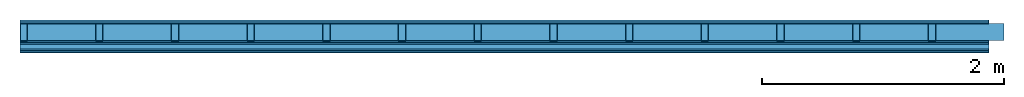
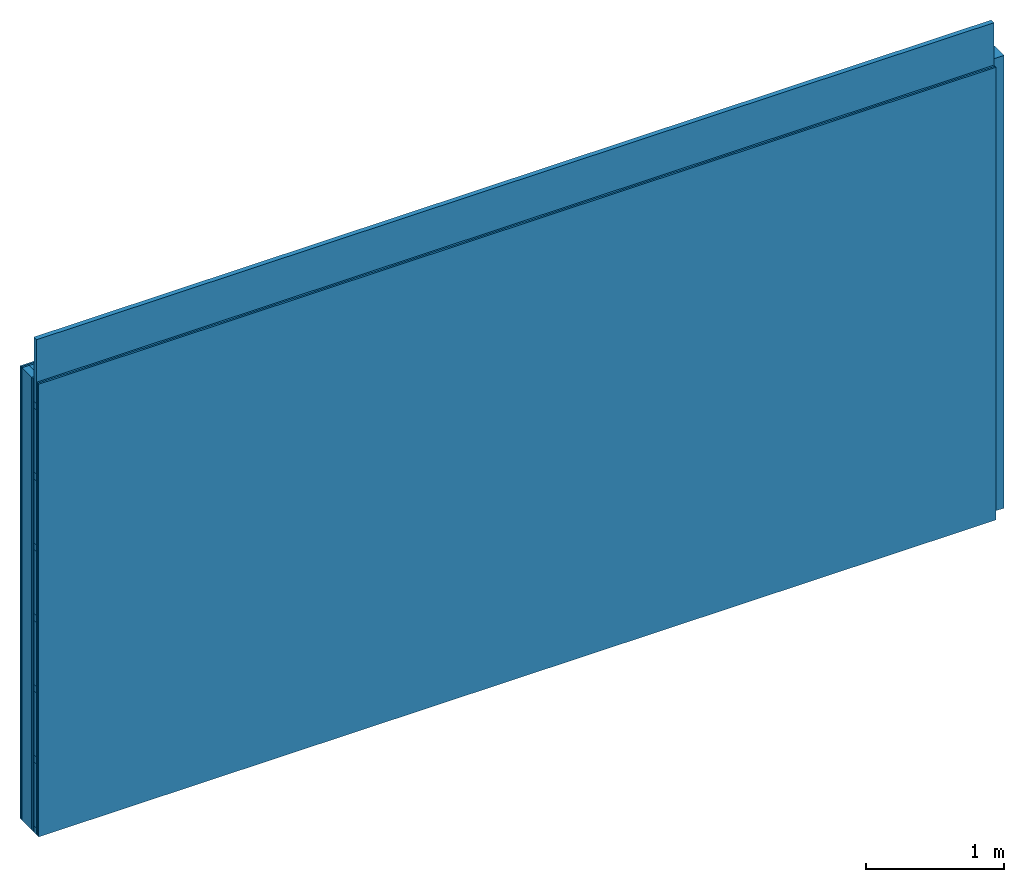
# One storey: 6 plates, 4 members, 1 element without a shape of its own.
"""IFC4 building model written with IfcOpenShell, lengths in metres."""

from ifc_helpers import new_model, si_unit, derived_unit, direction, frame, frame_2d, origin, origin_with_axes, place, context, project, spatial, rectangle, extrude, material, layer, layer_set, type_object, element, aggregate, save


model = new_model("IFC4")

# Units and contexts
plan_context = context("Plan", 3, precision=1e-05, world=origin(), true_north=direction((0.0, 1.0)))
model_context = context("Model", 3, precision=1e-05, world=origin(), true_north=direction((0.0, 1.0)))
ifc_project = project(units=[si_unit("LENGTHUNIT", "METRE"), derived_unit("SOUNDPRESSUREUNIT", [(si_unit("PRESSUREUNIT", "PASCAL", prefix="MICRO"), 0)]), si_unit("ENERGYUNIT", "JOULE", prefix="MEGA"), si_unit("MASSUNIT", "GRAM", prefix="KILO"), derived_unit("THERMALTRANSMITTANCEUNIT", [(si_unit("POWERUNIT", "WATT"), 1), (si_unit("AREAUNIT", "SQUARE_METRE"), -1), (si_unit("THERMODYNAMICTEMPERATUREUNIT", "KELVIN"), -1)]), derived_unit("AREADENSITYUNIT", [(si_unit("MASSUNIT", "GRAM", prefix="KILO"), 1), (si_unit("AREAUNIT", "SQUARE_METRE"), -1)]), derived_unit("USERDEFINED", [(si_unit("ENERGYUNIT", "JOULE", prefix="MEGA"), 1), (si_unit("AREAUNIT", "SQUARE_METRE"), -1)])], contexts=[plan_context, model_context])

# Site, building, storey
site = spatial("IfcSite", under=ifc_project)
building_placement = place(None, origin())
building = spatial("IfcBuilding", under=site, at=building_placement)
storey_placement = place(building_placement, origin())
storey = spatial("IfcBuildingStorey", under=building, at=storey_placement)

# Wall, members, plates
ifc_material_1 = material(Name="Glued joints")
ifc_layer_1 = layer(ifc_material_1, 0.0, Name="Surface")
ifc_material_2 = material(Category="03.007")
ifc_layer_2 = layer(ifc_material_2, 0.015, Name="2nd layer")
ifc_layer_3 = layer(ifc_material_2, 0.015, Name="1st layer")
ifc_material_3 = material(Name="of the art")
ifc_layer_4 = layer(ifc_material_3, 0.0, Name="Bond")
ifc_layer_5 = layer(None, 0.14, Name="Support")
ifc_layer_6 = layer(ifc_material_3, 0.0, Name="Bond")
ifc_layer_7 = layer(ifc_material_2, 0.015, Name="1st layer")
ifc_layer_8 = layer(ifc_material_2, 0.015, Name="2nd layer")
ifc_material_4 = material(Name="Substructure rigid")
ifc_layer_9 = layer(ifc_material_4, 0.0, Name="Coupling")
ifc_layer_10 = layer(None, 0.04, Name="Battens / profiles")
ifc_layer_11 = layer(ifc_material_2, 0.015, Name="Covering 1st layer")
ifc_layer_12 = layer(ifc_material_2, 0.015, Name="Covering 2nd layer")
ifc_layer_13 = layer(ifc_material_1, 0.0, Name="Surface")
ifc_layer_set = layer_set([ifc_layer_1, ifc_layer_2, ifc_layer_3, ifc_layer_4, ifc_layer_5, ifc_layer_6, ifc_layer_7, ifc_layer_8, ifc_layer_9, ifc_layer_10, ifc_layer_11, ifc_layer_12, ifc_layer_13])
wall_type = type_object("IfcWallType", Name="C0089", PredefinedType="NOTDEFINED", material=ifc_layer_set)
wall_placement = place(None, frame((0.0, 0.0, 0.0), z_axis=(0.0, -1.0, 0.0), x_axis=(1.0, 0.0, 0.0)))
wall = element("IfcWall", 1, at=wall_placement, inside=storey, type_object=wall_type, material=ifc_layer_set, Name="Wall #1")
ifc_material_5 = material()
member_1_placement = place(wall_placement, origin())
member_1 = element("IfcMember", 2, at=member_1_placement, material=ifc_material_5, Name="Support", context=plan_context, shape_type="SweptSolid", body=[
    extrude(rectangle(XDim=0.06, YDim=0.14, at=frame_2d((0.03, 0.07), x_axis=(1.0, 0.0))), frame((0.0, 4.0, 0.03), z_axis=(0.0, -1.0, 0.0), x_axis=(1.0, 0.0, 0.0)), (0.0, 0.0, 1.0), 4.0),
    extrude(rectangle(XDim=0.06, YDim=0.14, at=frame_2d((0.03, 0.07), x_axis=(1.0, 0.0))), frame((0.625, 4.0, 0.03), z_axis=(0.0, -1.0, 0.0), x_axis=(1.0, 0.0, 0.0)), (0.0, 0.0, 1.0), 4.0),
    extrude(rectangle(XDim=0.06, YDim=0.14, at=frame_2d((0.03, 0.07), x_axis=(1.0, 0.0))), frame((1.25, 4.0, 0.03), z_axis=(0.0, -1.0, 0.0), x_axis=(1.0, 0.0, 0.0)), (0.0, 0.0, 1.0), 4.0),
    extrude(rectangle(XDim=0.06, YDim=0.14, at=frame_2d((0.03, 0.07), x_axis=(1.0, 0.0))), frame((1.875, 4.0, 0.03), z_axis=(0.0, -1.0, 0.0), x_axis=(1.0, 0.0, 0.0)), (0.0, 0.0, 1.0), 4.0),
    extrude(rectangle(XDim=0.06, YDim=0.14, at=frame_2d((0.03, 0.07), x_axis=(1.0, 0.0))), frame((2.5, 4.0, 0.03), z_axis=(0.0, -1.0, 0.0), x_axis=(1.0, 0.0, 0.0)), (0.0, 0.0, 1.0), 4.0),
    extrude(rectangle(XDim=0.06, YDim=0.14, at=frame_2d((0.03, 0.07), x_axis=(1.0, 0.0))), frame((3.125, 4.0, 0.03), z_axis=(0.0, -1.0, 0.0), x_axis=(1.0, 0.0, 0.0)), (0.0, 0.0, 1.0), 4.0),
    extrude(rectangle(XDim=0.06, YDim=0.14, at=frame_2d((0.03, 0.07), x_axis=(1.0, 0.0))), frame((3.75, 4.0, 0.03), z_axis=(0.0, -1.0, 0.0), x_axis=(1.0, 0.0, 0.0)), (0.0, 0.0, 1.0), 4.0),
    extrude(rectangle(XDim=0.06, YDim=0.14, at=frame_2d((0.03, 0.07), x_axis=(1.0, 0.0))), frame((4.375, 4.0, 0.03), z_axis=(0.0, -1.0, 0.0), x_axis=(1.0, 0.0, 0.0)), (0.0, 0.0, 1.0), 4.0),
    extrude(rectangle(XDim=0.06, YDim=0.14, at=frame_2d((0.03, 0.07), x_axis=(1.0, 0.0))), frame((5.0, 4.0, 0.03), z_axis=(0.0, -1.0, 0.0), x_axis=(1.0, 0.0, 0.0)), (0.0, 0.0, 1.0), 4.0),
    extrude(rectangle(XDim=0.06, YDim=0.14, at=frame_2d((0.03, 0.07), x_axis=(1.0, 0.0))), frame((5.625, 4.0, 0.03), z_axis=(0.0, -1.0, 0.0), x_axis=(1.0, 0.0, 0.0)), (0.0, 0.0, 1.0), 4.0),
    extrude(rectangle(XDim=0.06, YDim=0.14, at=frame_2d((0.03, 0.07), x_axis=(1.0, 0.0))), frame((6.25, 4.0, 0.03), z_axis=(0.0, -1.0, 0.0), x_axis=(1.0, 0.0, 0.0)), (0.0, 0.0, 1.0), 4.0),
    extrude(rectangle(XDim=0.06, YDim=0.14, at=frame_2d((0.03, 0.07), x_axis=(1.0, 0.0))), frame((6.875, 4.0, 0.03), z_axis=(0.0, -1.0, 0.0), x_axis=(1.0, 0.0, 0.0)), (0.0, 0.0, 1.0), 4.0),
    extrude(rectangle(XDim=0.06, YDim=0.14, at=frame_2d((0.03, 0.07), x_axis=(1.0, 0.0))), frame((7.5, 4.0, 0.03), z_axis=(0.0, -1.0, 0.0), x_axis=(1.0, 0.0, 0.0)), (0.0, 0.0, 1.0), 4.0),
])
ifc_material_6 = material()
member_2_placement = place(wall_placement, origin())
member_2 = element("IfcMember", 3, at=member_2_placement, material=ifc_material_6, Name="Cavity", context=plan_context, shape_type="SweptSolid", body=[
    extrude(rectangle(XDim=0.565, YDim=0.14, at=frame_2d((0.2825, 0.07), x_axis=(1.0, 0.0))), frame((0.06, 4.0, 0.03), z_axis=(0.0, -1.0, 0.0), x_axis=(1.0, 0.0, 0.0)), (0.0, 0.0, 1.0), 4.0),
    extrude(rectangle(XDim=0.565, YDim=0.14, at=frame_2d((0.2825, 0.07), x_axis=(1.0, 0.0))), frame((0.685, 4.0, 0.03), z_axis=(0.0, -1.0, 0.0), x_axis=(1.0, 0.0, 0.0)), (0.0, 0.0, 1.0), 4.0),
    extrude(rectangle(XDim=0.565, YDim=0.14, at=frame_2d((0.2825, 0.07), x_axis=(1.0, 0.0))), frame((1.31, 4.0, 0.03), z_axis=(0.0, -1.0, 0.0), x_axis=(1.0, 0.0, 0.0)), (0.0, 0.0, 1.0), 4.0),
    extrude(rectangle(XDim=0.565, YDim=0.14, at=frame_2d((0.2825, 0.07), x_axis=(1.0, 0.0))), frame((1.935, 4.0, 0.03), z_axis=(0.0, -1.0, 0.0), x_axis=(1.0, 0.0, 0.0)), (0.0, 0.0, 1.0), 4.0),
    extrude(rectangle(XDim=0.565, YDim=0.14, at=frame_2d((0.2825, 0.07), x_axis=(1.0, 0.0))), frame((2.56, 4.0, 0.03), z_axis=(0.0, -1.0, 0.0), x_axis=(1.0, 0.0, 0.0)), (0.0, 0.0, 1.0), 4.0),
    extrude(rectangle(XDim=0.565, YDim=0.14, at=frame_2d((0.2825, 0.07), x_axis=(1.0, 0.0))), frame((3.185, 4.0, 0.03), z_axis=(0.0, -1.0, 0.0), x_axis=(1.0, 0.0, 0.0)), (0.0, 0.0, 1.0), 4.0),
    extrude(rectangle(XDim=0.565, YDim=0.14, at=frame_2d((0.2825, 0.07), x_axis=(1.0, 0.0))), frame((3.81, 4.0, 0.03), z_axis=(0.0, -1.0, 0.0), x_axis=(1.0, 0.0, 0.0)), (0.0, 0.0, 1.0), 4.0),
    extrude(rectangle(XDim=0.565, YDim=0.14, at=frame_2d((0.2825, 0.07), x_axis=(1.0, 0.0))), frame((4.435, 4.0, 0.03), z_axis=(0.0, -1.0, 0.0), x_axis=(1.0, 0.0, 0.0)), (0.0, 0.0, 1.0), 4.0),
    extrude(rectangle(XDim=0.565, YDim=0.14, at=frame_2d((0.2825, 0.07), x_axis=(1.0, 0.0))), frame((5.06, 4.0, 0.03), z_axis=(0.0, -1.0, 0.0), x_axis=(1.0, 0.0, 0.0)), (0.0, 0.0, 1.0), 4.0),
    extrude(rectangle(XDim=0.565, YDim=0.14, at=frame_2d((0.2825, 0.07), x_axis=(1.0, 0.0))), frame((5.685, 4.0, 0.03), z_axis=(0.0, -1.0, 0.0), x_axis=(1.0, 0.0, 0.0)), (0.0, 0.0, 1.0), 4.0),
    extrude(rectangle(XDim=0.565, YDim=0.14, at=frame_2d((0.2825, 0.07), x_axis=(1.0, 0.0))), frame((6.31, 4.0, 0.03), z_axis=(0.0, -1.0, 0.0), x_axis=(1.0, 0.0, 0.0)), (0.0, 0.0, 1.0), 4.0),
    extrude(rectangle(XDim=0.565, YDim=0.14, at=frame_2d((0.2825, 0.07), x_axis=(1.0, 0.0))), frame((6.935, 4.0, 0.03), z_axis=(0.0, -1.0, 0.0), x_axis=(1.0, 0.0, 0.0)), (0.0, 0.0, 1.0), 4.0),
    extrude(rectangle(XDim=0.565, YDim=0.14, at=frame_2d((0.2825, 0.07), x_axis=(1.0, 0.0))), frame((7.56, 4.0, 0.03), z_axis=(0.0, -1.0, 0.0), x_axis=(1.0, 0.0, 0.0)), (0.0, 0.0, 1.0), 4.0),
])
ifc_material_7 = material()
member_3_placement = place(wall_placement, origin())
member_3 = element("IfcMember", 4, at=member_3_placement, material=ifc_material_7, Name="Battens / profiles", context=plan_context, shape_type="SweptSolid", body=[
    extrude(rectangle(XDim=0.06, YDim=0.04, at=frame_2d((0.03, 0.02), x_axis=(1.0, 0.0))), frame((0.0, 0.0, 0.2), z_axis=(1.0, 0.0, 0.0), x_axis=(0.0, 1.0, 0.0)), (0.0, 0.0, 1.0), 8.0),
    extrude(rectangle(XDim=0.06, YDim=0.04, at=frame_2d((0.03, 0.02), x_axis=(1.0, 0.0))), frame((0.0, 0.625, 0.2), z_axis=(1.0, 0.0, 0.0), x_axis=(0.0, 1.0, 0.0)), (0.0, 0.0, 1.0), 8.0),
    extrude(rectangle(XDim=0.06, YDim=0.04, at=frame_2d((0.03, 0.02), x_axis=(1.0, 0.0))), frame((0.0, 1.25, 0.2), z_axis=(1.0, 0.0, 0.0), x_axis=(0.0, 1.0, 0.0)), (0.0, 0.0, 1.0), 8.0),
    extrude(rectangle(XDim=0.06, YDim=0.04, at=frame_2d((0.03, 0.02), x_axis=(1.0, 0.0))), frame((0.0, 1.875, 0.2), z_axis=(1.0, 0.0, 0.0), x_axis=(0.0, 1.0, 0.0)), (0.0, 0.0, 1.0), 8.0),
    extrude(rectangle(XDim=0.06, YDim=0.04, at=frame_2d((0.03, 0.02), x_axis=(1.0, 0.0))), frame((0.0, 2.5, 0.2), z_axis=(1.0, 0.0, 0.0), x_axis=(0.0, 1.0, 0.0)), (0.0, 0.0, 1.0), 8.0),
    extrude(rectangle(XDim=0.06, YDim=0.04, at=frame_2d((0.03, 0.02), x_axis=(1.0, 0.0))), frame((0.0, 3.125, 0.2), z_axis=(1.0, 0.0, 0.0), x_axis=(0.0, 1.0, 0.0)), (0.0, 0.0, 1.0), 8.0),
    extrude(rectangle(XDim=0.06, YDim=0.04, at=frame_2d((0.03, 0.02), x_axis=(1.0, 0.0))), frame((0.0, 3.75, 0.2), z_axis=(1.0, 0.0, 0.0), x_axis=(0.0, 1.0, 0.0)), (0.0, 0.0, 1.0), 8.0),
])
member_4_placement = place(wall_placement, origin())
member_4 = element("IfcMember", 5, at=member_4_placement, material=ifc_material_6, Name="Cavity", context=plan_context, shape_type="SweptSolid", body=[
    extrude(rectangle(XDim=0.565, YDim=0.04, at=frame_2d((0.2825, 0.02), x_axis=(1.0, 0.0))), frame((0.0, 0.06, 0.2), z_axis=(1.0, 0.0, 0.0), x_axis=(0.0, 1.0, 0.0)), (0.0, 0.0, 1.0), 8.0),
    extrude(rectangle(XDim=0.565, YDim=0.04, at=frame_2d((0.2825, 0.02), x_axis=(1.0, 0.0))), frame((0.0, 0.685, 0.2), z_axis=(1.0, 0.0, 0.0), x_axis=(0.0, 1.0, 0.0)), (0.0, 0.0, 1.0), 8.0),
    extrude(rectangle(XDim=0.565, YDim=0.04, at=frame_2d((0.2825, 0.02), x_axis=(1.0, 0.0))), frame((0.0, 1.31, 0.2), z_axis=(1.0, 0.0, 0.0), x_axis=(0.0, 1.0, 0.0)), (0.0, 0.0, 1.0), 8.0),
    extrude(rectangle(XDim=0.565, YDim=0.04, at=frame_2d((0.2825, 0.02), x_axis=(1.0, 0.0))), frame((0.0, 1.935, 0.2), z_axis=(1.0, 0.0, 0.0), x_axis=(0.0, 1.0, 0.0)), (0.0, 0.0, 1.0), 8.0),
    extrude(rectangle(XDim=0.565, YDim=0.04, at=frame_2d((0.2825, 0.02), x_axis=(1.0, 0.0))), frame((0.0, 2.56, 0.2), z_axis=(1.0, 0.0, 0.0), x_axis=(0.0, 1.0, 0.0)), (0.0, 0.0, 1.0), 8.0),
    extrude(rectangle(XDim=0.565, YDim=0.04, at=frame_2d((0.2825, 0.02), x_axis=(1.0, 0.0))), frame((0.0, 3.185, 0.2), z_axis=(1.0, 0.0, 0.0), x_axis=(0.0, 1.0, 0.0)), (0.0, 0.0, 1.0), 8.0),
    extrude(rectangle(XDim=0.565, YDim=0.04, at=frame_2d((0.2825, 0.02), x_axis=(1.0, 0.0))), frame((0.0, 3.81, 0.2), z_axis=(1.0, 0.0, 0.0), x_axis=(0.0, 1.0, 0.0)), (0.0, 0.0, 1.0), 8.0),
])
plate_1_placement = place(wall_placement, origin())
plate_1 = element("IfcPlate", 6, at=plate_1_placement, material=ifc_material_2, Name="2nd layer", context=plan_context, shape_type="SweptSolid", body=[
    extrude(rectangle(XDim=8.0, YDim=4.0, at=frame_2d((4.0, 2.0), x_axis=(1.0, 0.0))), origin_with_axes(), (0.0, 0.0, 1.0), 0.015),
])
plate_2_placement = place(wall_placement, origin())
plate_2 = element("IfcPlate", 7, at=plate_2_placement, material=ifc_material_2, Name="1st layer", context=plan_context, shape_type="SweptSolid", body=[
    extrude(rectangle(XDim=8.0, YDim=4.0, at=frame_2d((4.0, 2.0), x_axis=(1.0, 0.0))), frame((0.0, 0.0, 0.015), z_axis=(0.0, 0.0, 1.0), x_axis=(1.0, 0.0, 0.0)), (0.0, 0.0, 1.0), 0.015),
])
plate_3_placement = place(wall_placement, origin())
plate_3 = element("IfcPlate", 8, at=plate_3_placement, material=ifc_material_2, Name="1st layer", context=plan_context, shape_type="SweptSolid", body=[
    extrude(rectangle(XDim=8.0, YDim=4.0, at=frame_2d((4.0, 2.0), x_axis=(1.0, 0.0))), frame((0.0, 0.0, 0.17), z_axis=(0.0, 0.0, 1.0), x_axis=(1.0, 0.0, 0.0)), (0.0, 0.0, 1.0), 0.015),
])
plate_4_placement = place(wall_placement, origin())
plate_4 = element("IfcPlate", 9, at=plate_4_placement, material=ifc_material_2, Name="2nd layer", context=plan_context, shape_type="SweptSolid", body=[
    extrude(rectangle(XDim=8.0, YDim=4.0, at=frame_2d((4.0, 2.0), x_axis=(1.0, 0.0))), frame((0.0, 0.0, 0.185), z_axis=(0.0, 0.0, 1.0), x_axis=(1.0, 0.0, 0.0)), (0.0, 0.0, 1.0), 0.015),
])
plate_5_placement = place(wall_placement, origin())
plate_5 = element("IfcPlate", 10, at=plate_5_placement, material=ifc_material_2, Name="Covering 1st layer", context=plan_context, shape_type="SweptSolid", body=[
    extrude(rectangle(XDim=8.0, YDim=4.0, at=frame_2d((4.0, 2.0), x_axis=(1.0, 0.0))), frame((0.0, 0.0, 0.24), z_axis=(0.0, 0.0, 1.0), x_axis=(1.0, 0.0, 0.0)), (0.0, 0.0, 1.0), 0.015),
])
plate_6_placement = place(wall_placement, origin())
plate_6 = element("IfcPlate", 11, at=plate_6_placement, material=ifc_material_2, Name="Covering 2nd layer", context=plan_context, shape_type="SweptSolid", body=[
    extrude(rectangle(XDim=8.0, YDim=4.0, at=frame_2d((4.0, 2.0), x_axis=(1.0, 0.0))), frame((0.0, 0.0, 0.255), z_axis=(0.0, 0.0, 1.0), x_axis=(1.0, 0.0, 0.0)), (0.0, 0.0, 1.0), 0.015),
])
aggregate(wall, [plate_1, plate_2, member_1, member_2, plate_3, plate_4, member_3, member_4, plate_5, plate_6])

save(model, "model.ifc")
